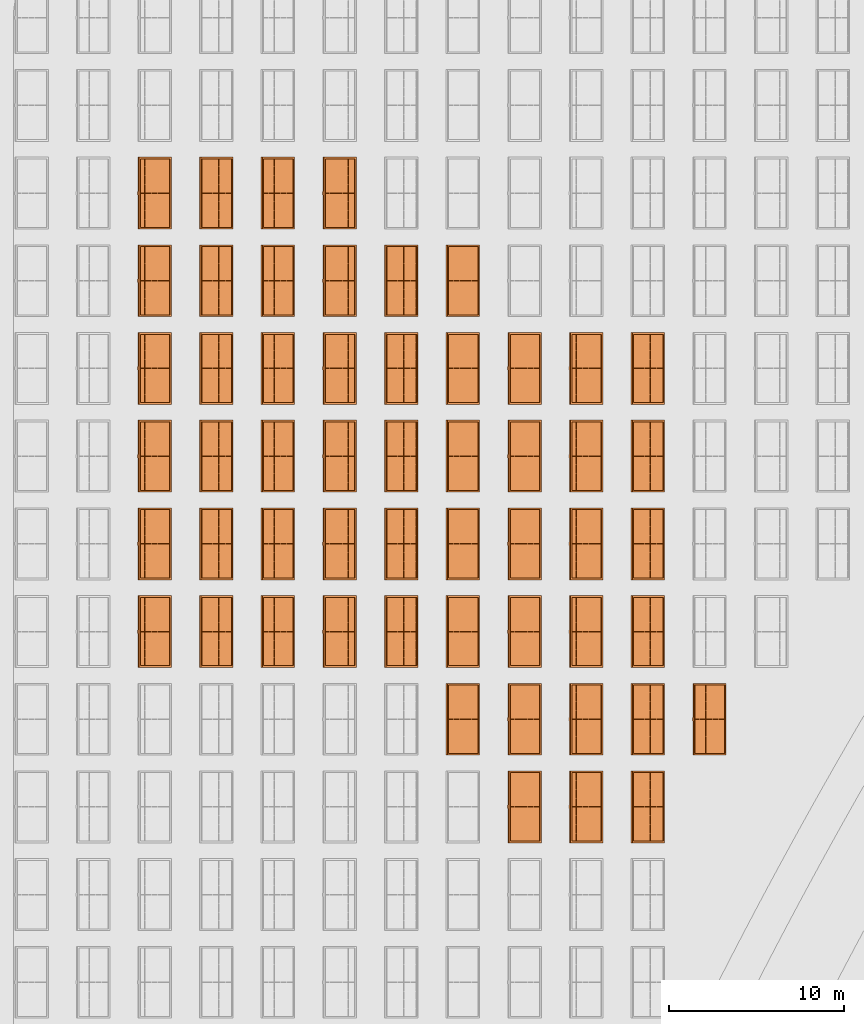
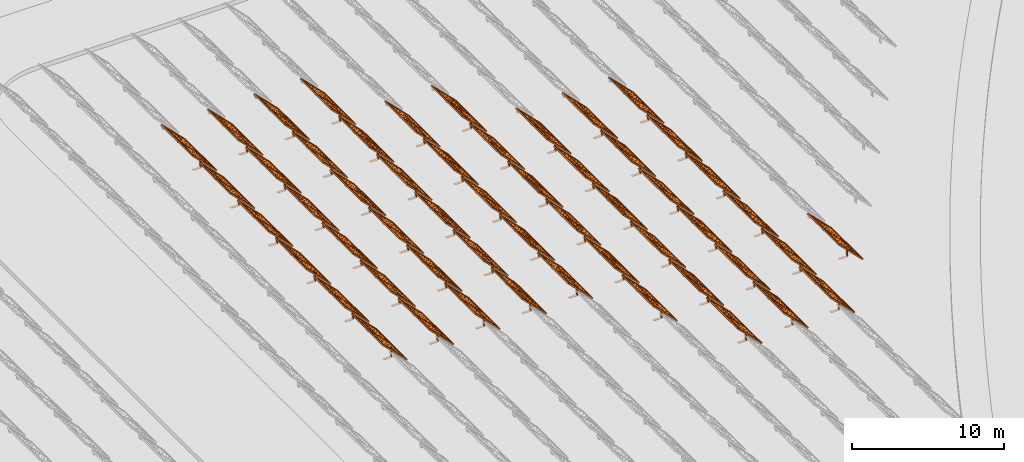
# One storey, part 31 of 39: 54 proxies.
"""IFC2X3 building model written with IfcOpenShell, lengths in millimetres."""

import ifcopenshell
import ifcopenshell.guid

model = None  # the IFC model being written
_history = None  # IfcOwnerHistory: only IFC2X3 demands one
_inside = {}  # id of a spatial element -> (the spatial element, [elements in it])
_under = {}  # id of a project, library or spatial element -> (it, [spatial elements below it])
_declared = {}  # id of a project -> (the project, [libraries it declares])
_typed = {}  # id of a type object -> (the type object, [elements of that type])
_made_of = {}  # id of a material, layer set ... -> (it, [elements and type objects made of it])


def new_model(schema):
    """Start an empty IFC model of exactly this schema.

    Asked for "IFC4X3", IfcOpenShell would pick the latest addendum, in which some entities
    have other attributes; the version numbers below select the first issue.
    IFC2X3 requires an IfcOwnerHistory on every rooted entity: one is made here for all.
    """
    global model, _history
    if schema == "IFC4X3":
        model = ifcopenshell.file(schema_version=(4, 3, 0, 0))
    else:
        model = ifcopenshell.file(schema=schema)
    _inside.clear()
    _under.clear()
    _declared.clear()
    _typed.clear()
    _made_of.clear()
    _history = None
    if model.schema == "IFC2X3":
        org = make("IfcOrganization", Name="unknown")
        user = make(
            "IfcPersonAndOrganization",
            ThePerson=make("IfcPerson", FamilyName="unknown"),
            TheOrganization=org,
        )
        app = make(
            "IfcApplication",
            ApplicationDeveloper=org,
            Version="unknown",
            ApplicationFullName="unknown",
            ApplicationIdentifier="unknown",
        )
        _history = make(
            "IfcOwnerHistory",
            OwningUser=user,
            OwningApplication=app,
            ChangeAction="ADDED",
            CreationDate=0,
        )
    return model


def make(cls, **values):
    """One entity of the class cls with the attributes given. An attribute that is None is left unset."""
    return model.create_entity(
        cls, **{name: value for name, value in values.items() if value is not None}
    )


def entity(cls, *values):
    """Any entity or typed value of the class cls, its attributes in the order of the schema. None: left unset."""
    e = model.create_entity(cls)
    for i, value in enumerate(values):
        if value is not None:
            e[i] = value
    return e


def rooted(cls, **values):
    """An entity with a GlobalId (a new one), such as an element, a storey or a relation."""
    return make(cls, GlobalId=ifcopenshell.guid.new(), OwnerHistory=_history, **values)


def si_unit(unit_type, name, prefix=None):
    """IfcSIUnit, for example si_unit("LENGTHUNIT", "METRE", prefix="MILLI")."""
    return make("IfcSIUnit", UnitType=unit_type, Prefix=prefix, Name=name)


def converted_unit(unit_type, name, factor, base, dimensions=None, offset=None):
    """IfcConversionBasedUnit, such as the inch: factor (a typed value) times the base unit."""
    return make(
        "IfcConversionBasedUnit"
        if offset is None
        else "IfcConversionBasedUnitWithOffset",
        ConversionOffset=offset,
        Dimensions=None
        if dimensions is None
        else entity("IfcDimensionalExponents", *dimensions),
        UnitType=unit_type,
        Name=name,
        ConversionFactor=make(
            "IfcMeasureWithUnit", ValueComponent=factor, UnitComponent=base
        ),
    )


def derived_unit(unit_type, elements):
    """IfcDerivedUnit: a product of units, each with its exponent."""
    return make(
        "IfcDerivedUnit",
        Elements=[
            make("IfcDerivedUnitElement", Unit=unit, Exponent=power)
            for unit, power in elements
        ],
        UnitType=unit_type,
    )


def assignment(units):
    """IfcUnitAssignment: the units of a project."""
    return None if units is None else make("IfcUnitAssignment", Units=units)


def point(xyz):
    """IfcCartesianPoint."""
    return None if xyz is None else make("IfcCartesianPoint", Coordinates=xyz)


def direction(xyz):
    """IfcDirection."""
    return None if xyz is None else make("IfcDirection", DirectionRatios=xyz)


def frame(location, z_axis=None, x_axis=None):
    """IfcAxis2Placement3D, a coordinate frame: its origin and axes. An axis left out is left unset."""
    return make(
        "IfcAxis2Placement3D",
        Location=point(location),
        Axis=direction(z_axis),
        RefDirection=direction(x_axis),
    )


def frame_2d(location, x_axis=None):
    """IfcAxis2Placement2D, a coordinate frame in the plane: its origin and x axis."""
    return make(
        "IfcAxis2Placement2D", Location=point(location), RefDirection=direction(x_axis)
    )


def origin():
    """The frame at (0, 0, 0) with its axes left unset."""
    return frame((0.0, 0.0, 0.0))


def origin_2d_with_axis():
    """The frame at (0, 0) in the plane with the x axis (1, 0) written out."""
    return frame_2d((0.0, 0.0), x_axis=(1.0, 0.0))


def place(relative_to, where):
    """IfcLocalPlacement: puts the frame where relative to a parent placement (None: the world)."""
    return make(
        "IfcLocalPlacement", PlacementRelTo=relative_to, RelativePlacement=where
    )


def context(
    kind, dimensions, precision=None, world=None, true_north=None, identifier=None
):
    """IfcGeometricRepresentationContext, for example the 3D "Model" context."""
    return make(
        "IfcGeometricRepresentationContext",
        ContextIdentifier=identifier,
        ContextType=kind,
        CoordinateSpaceDimension=dimensions,
        Precision=precision,
        WorldCoordinateSystem=world,
        TrueNorth=true_north,
    )


def subcontext(parent, identifier, kind, view, scale=None):
    """IfcGeometricRepresentationSubContext, for example "Body" below "Model"."""
    return make(
        "IfcGeometricRepresentationSubContext",
        ContextIdentifier=identifier,
        ContextType=kind,
        ParentContext=parent,
        TargetScale=scale,
        TargetView=view,
    )


def project(units=None, contexts=None):
    """IfcProject with its units and contexts."""
    return rooted(
        "IfcProject",
        Name="project",
        RepresentationContexts=contexts,
        UnitsInContext=assignment(units),
    )


def spatial(cls, under=None, at=None, **own):
    """A site, building, storey or space (cls), placed at a placement, below another one or the project."""
    s = rooted(cls, ObjectPlacement=at, **own)
    if under is not None:
        _under.setdefault(under.id(), (under, []))[1].append(s)
    return s


def polyline(points):
    """IfcPolyline through the points."""
    return make("IfcPolyline", Points=[point(p) for p in points])


def profile(cls, at=None, kind="AREA", **sizes):
    """A parametric profile (cls). Its sizes go by their IFC names, for example OverallWidth=200.0."""
    return make(cls, ProfileType=kind, Position=at, **sizes)


def rectangle(**sizes):
    """IfcRectangleProfileDef."""
    return profile("IfcRectangleProfileDef", **sizes)


def outline(outer, holes=None, kind="AREA"):
    """IfcArbitraryClosedProfileDef: a profile drawn as a closed curve; with holes, ...WithVoids."""
    if holes is None:
        return make("IfcArbitraryClosedProfileDef", ProfileType=kind, OuterCurve=outer)
    return make(
        "IfcArbitraryProfileDefWithVoids",
        ProfileType=kind,
        OuterCurve=outer,
        InnerCurves=holes,
    )


def extrude(swept, where, along, depth):
    """IfcExtrudedAreaSolid: the profile swept, set in the frame where, extruded along a direction by depth."""
    return make(
        "IfcExtrudedAreaSolid",
        SweptArea=swept,
        Position=where,
        ExtrudedDirection=direction(along),
        Depth=depth,
    )


def shape(context_of_items, identifier, shape_type, items):
    """IfcShapeRepresentation: the items that make up one representation, for example the "Body"."""
    return make(
        "IfcShapeRepresentation",
        ContextOfItems=context_of_items,
        RepresentationIdentifier=identifier,
        RepresentationType=shape_type,
        Items=items,
    )


def source(mapping_origin, context_of_items, identifier, shape_type, items):
    """IfcRepresentationMap: a shape defined once, which mapped items show again and again."""
    return make(
        "IfcRepresentationMap",
        MappingOrigin=mapping_origin,
        MappedRepresentation=shape(context_of_items, identifier, shape_type, items),
    )


def transform(
    local_origin,
    x_axis=None,
    y_axis=None,
    z_axis=None,
    scale=None,
    scale2=None,
    scale3=None,
    uniform=True,
):
    """IfcCartesianTransformationOperator3D, or its non-uniform kind. x_axis, y_axis, z_axis: its Axis1, 2, 3."""
    if uniform:
        return make(
            "IfcCartesianTransformationOperator3D",
            Axis1=direction(x_axis),
            Axis2=direction(y_axis),
            LocalOrigin=point(local_origin),
            Scale=scale,
            Axis3=direction(z_axis),
        )
    return make(
        "IfcCartesianTransformationOperator3DnonUniform",
        Axis1=direction(x_axis),
        Axis2=direction(y_axis),
        LocalOrigin=point(local_origin),
        Scale=scale,
        Axis3=direction(z_axis),
        Scale2=scale2,
        Scale3=scale3,
    )


def mapped(mapping_source, mapping_target):
    """IfcMappedItem: shows the shape of a source again, moved by a transform."""
    return make(
        "IfcMappedItem", MappingSource=mapping_source, MappingTarget=mapping_target
    )


def material(Name=None, Category=None):
    """IfcMaterial."""
    return make("IfcMaterial", Name=Name, Category=Category)


def material_list(materials):
    """IfcMaterialList."""
    return make("IfcMaterialList", Materials=materials)


def made_of(thing, what):
    """Note that an element or type object is made of a material, layer set ...; save() writes the relation."""
    if what is not None:
        _made_of.setdefault(what.id(), (what, []))[1].append(thing)
    return thing


def element(
    cls,
    number,
    at=None,
    inside=None,
    cuts=None,
    type_object=None,
    material=None,
    context=None,
    identifier="Body",
    shape_type=None,
    held_by="IfcProductDefinitionShape",
    body=None,
    shapes=None,
    **own,
):
    """One element of the class cls, such as IfcWall. Its Tag is "e" and its number.

    at: its placement. inside: the storey or other place that contains it. cuts: it is an
    opening in that element (IfcRelVoidsElement). A single representation is given by context,
    identifier, shape_type and body (its items); several are given by shapes. held_by: the class
    of the entity that holds the representations. save() writes the other relations.
    """
    e = rooted(cls, Tag="e%d" % number, ObjectPlacement=at, **own)
    if body is not None:
        shapes = [shape(context, identifier, shape_type, body)]
    if shapes is not None:
        e.Representation = make(held_by, Representations=shapes)
    if inside is not None:
        _inside.setdefault(inside.id(), (inside, []))[1].append(e)
    if cuts is not None:
        rooted(
            "IfcRelVoidsElement", RelatingBuildingElement=cuts, RelatedOpeningElement=e
        )
    if type_object is not None:
        _typed.setdefault(type_object.id(), (type_object, []))[1].append(e)
    return made_of(e, material)


def aggregate(whole, parts):
    """IfcRelAggregates: a whole, such as a stair, and the parts it consists of."""
    return rooted("IfcRelAggregates", RelatingObject=whole, RelatedObjects=parts)


def save(model, path):
    """Write the relations noted so far, then the file.

    IfcRelAggregates (storeys below a building ...), IfcRelContainedInSpatialStructure (elements
    in a storey), IfcRelDefinesByType, IfcRelAssociatesMaterial and IfcRelDeclares: one each for
    every whole, place, type object, material and project.
    """
    for whole, parts in _under.values():
        aggregate(whole, parts)
    for where, things in _inside.values():
        rooted(
            "IfcRelContainedInSpatialStructure",
            RelatedElements=things,
            RelatingStructure=where,
        )
    for kind, things in _typed.values():
        rooted("IfcRelDefinesByType", RelatedObjects=things, RelatingType=kind)
    for what, things in _made_of.values():
        rooted("IfcRelAssociatesMaterial", RelatedObjects=things, RelatingMaterial=what)
    for by, libraries in _declared.values():
        rooted("IfcRelDeclares", RelatingContext=by, RelatedDefinitions=libraries)
    model.write(path)


model = new_model("IFC2X3")

# Units and contexts
model_context = context("Model", 3, precision=1e-06, world=origin(), true_north=direction((2.0, 6.12303176911189e-17, 1.0)))
context_of_model = context(None, 3, precision=1e-06, world=origin(), true_north=direction((2.0, 6.12303176911189e-17, 1.0)))
body_context = subcontext(model_context, "Body", "Model", "MODEL_VIEW")
ifc_project = project(units=[si_unit("LENGTHUNIT", "METRE", prefix="MILLI"), si_unit("AREAUNIT", "SQUARE_METRE", prefix="MILLI"), si_unit("VOLUMEUNIT", "CUBIC_METRE", prefix="MILLI"), converted_unit("PLANEANGLEUNIT", "DEGREE", entity("IfcRatioMeasure", 0.0174532925199433), si_unit("PLANEANGLEUNIT", "RADIAN"), dimensions=[0, 0, 0, 0, 0, 0, 0]), si_unit("MASSUNIT", "GRAM", prefix="KILO"), si_unit("TIMEUNIT", "SECOND"), si_unit("THERMODYNAMICTEMPERATUREUNIT", "KELVIN"), derived_unit("THERMALTRANSMITTANCEUNIT", [(si_unit("MASSUNIT", "GRAM", prefix="KILO"), 1), (si_unit("THERMODYNAMICTEMPERATUREUNIT", "KELVIN"), -1), (si_unit("TIMEUNIT", "SECOND"), -3)]), derived_unit("VOLUMETRICFLOWRATEUNIT", [(si_unit("LENGTHUNIT", "METRE"), 3), (si_unit("TIMEUNIT", "SECOND"), -1)])], contexts=[model_context, context_of_model])

# Site, building, storey
site_placement = place(None, origin())
site = spatial("IfcSite", under=ifc_project, at=site_placement, CompositionType="ELEMENT")
building_placement = place(site_placement, origin())
building = spatial("IfcBuilding", under=site, at=building_placement, CompositionType="ELEMENT")
storey_placement = place(building_placement, frame((0.0, 0.0, 4000.0)))
storey = spatial("IfcBuildingStorey", under=building, at=storey_placement, Name="Level 2", CompositionType="ELEMENT", Elevation=4000.0)

# Proxies
ifc_material_1 = material(Name="Stand-Steel")
ifc_material_2 = material(Name="Aluminium")
ifc_material_3 = material(Name="Glass")
ifc_material_list_1 = material_list([ifc_material_1, ifc_material_2, ifc_material_3])
shared_shape = source(origin(), body_context, "Body", "SweptSolid", [
    extrude(outline(polyline([(-629.526235435404, -220.0), (329.763117717702, -220.0), (329.763117717703, 410.0), (299.763117717703, 410.0), (299.763117717702, -190.0), (-629.526235435404, -190.0), (-629.526235435404, -220.0)])), frame((-190.00003127179, -100.0, 299.763117717707), z_axis=(0.0, 1.0, 0.0), x_axis=(0.0, 0.0, -1.0)), (0.0, 0.0, 1.0), 200.0),
    extrude(rectangle(XDim=20.0000000000001, YDim=200.0, at=frame_2d((0.0, -7.105427357601e-14), x_axis=(0.0, 1.0))), frame((-7.07109908365613, 0.0, 922.21828534124), z_axis=(-0.70710678118654, 0.0, 0.707106781186555), x_axis=(0.0, 1.0, 0.0)), (0.0, 0.0, 1.0), 2600.0),
    extrude(rectangle(XDim=24.9999999999997, YDim=24.9999999999999, at=frame_2d((2.87769807982841e-13, -9.50350909079134e-14), x_axis=(1.0, 0.0))), frame((-1449.56292018118, -1950.0, 2449.57494522722), z_axis=(0.0, 1.0, 0.0), x_axis=(-0.707106781186548, 0.0, -0.707106781186548)), (0.0, 0.0, 1.0), 3900.0),
    extrude(rectangle(XDim=24.9999999999999, YDim=25.0000000000001, at=origin_2d_with_axis()), frame((-1096.0095295879, -1950.0, 2096.02155463395), z_axis=(0.0, 1.0, 0.0), x_axis=(-0.707106781186542, 0.0, -0.707106781186553)), (0.0, 0.0, 1.0), 3900.0),
    extrude(rectangle(XDim=24.9999999999999, YDim=25.0000000000001, at=origin_2d_with_axis()), frame((-742.456138994631, -1950.0, 1742.46816404067), z_axis=(0.0, 1.0, 0.0), x_axis=(-0.707106781186542, 0.0, -0.707106781186553)), (0.0, 0.0, 1.0), 3900.0),
    extrude(rectangle(XDim=25.0, YDim=24.9999999999997, at=frame_2d((-7.19424519957101e-14, 1.19904086659517e-13), x_axis=(1.0, 0.0))), frame((-388.902748401358, -1950.0, 1388.9147734474), z_axis=(0.0, 1.0, 0.0), x_axis=(-0.707106781186545, 0.0, -0.70710678118655)), (0.0, 0.0, 1.0), 3900.0),
    extrude(rectangle(XDim=25.0000000000002, YDim=25.0, at=frame_2d((1.35891298214119e-13, 6.21724893790088e-15), x_axis=(0.0, 1.0))), frame((-35.3553703311048, 1500.0, 1035.35537033109), z_axis=(-0.707106781186544, 0.0, 0.707106781186551), x_axis=(0.0, 1.0, 0.0)), (0.0, 0.0, 1.0), 2440.0),
    extrude(rectangle(XDim=25.0000000000002, YDim=25.0, at=frame_2d((0.0, 1.77635683940025e-15), x_axis=(0.0, 1.0))), frame((-35.3553703311059, 1000.0, 1035.35537033109), z_axis=(-0.707106781186546, 0.0, 0.707106781186549), x_axis=(0.0, 1.0, 0.0)), (0.0, 0.0, 1.0), 2440.0),
    extrude(rectangle(XDim=25.0000000000002, YDim=25.0, at=frame_2d((0.0, 8.43769498715119e-14), x_axis=(0.0, 1.0))), frame((-26.5165355662756, 0.0, 1044.19420509593), z_axis=(-0.707106781186546, 0.0, 0.707106781186549), x_axis=(0.0, -1.0, 0.0)), (0.0, 0.0, 1.0), 2440.0),
    extrude(rectangle(XDim=25.0000000000002, YDim=25.0, at=frame_2d((0.0, 8.88178419700125e-16), x_axis=(0.0, 1.0))), frame((-35.3553703311065, 500.0, 1035.35537033109), z_axis=(-0.707106781186546, 0.0, 0.707106781186549), x_axis=(0.0, 1.0, 0.0)), (0.0, 0.0, 1.0), 2440.0),
    extrude(rectangle(XDim=25.0000000000002, YDim=25.0, at=frame_2d((0.0, 8.88178419700125e-16), x_axis=(0.0, 1.0))), frame((-35.3553703311086, -500.0, 1035.35537033109), z_axis=(-0.707106781186546, 0.0, 0.707106781186549), x_axis=(0.0, 1.0, 0.0)), (0.0, 0.0, 1.0), 2440.0),
    extrude(rectangle(XDim=25.0000000000002, YDim=25.0, at=frame_2d((0.0, 8.88178419700125e-16), x_axis=(0.0, 1.0))), frame((-35.3553703311095, -1000.0, 1035.35537033109), z_axis=(-0.707106781186546, 0.0, 0.707106781186549), x_axis=(0.0, 1.0, 0.0)), (0.0, 0.0, 1.0), 2440.0),
    extrude(rectangle(XDim=25.0000000000002, YDim=25.0, at=frame_2d((1.35891298214119e-13, 1.77635683940025e-15), x_axis=(0.0, 1.0))), frame((-35.3553703311107, -1500.0, 1035.35537033109), z_axis=(-0.707106781186546, 0.0, 0.707106781186549), x_axis=(0.0, 1.0, 0.0)), (0.0, 0.0, 1.0), 2440.0),
    extrude(rectangle(XDim=2400.0, YDim=11.9999999999994, at=frame_2d((-1.13686837721616e-13, 2.02948768901479e-13), x_axis=(1.0, 0.0))), frame((-883.883507754966, -1950.0, 1883.88350775495), z_axis=(0.0, 1.0, 0.0), x_axis=(0.707106781186546, 0.0, -0.707106781186549)), (0.0, 0.0, 1.0), 3900.0),
    extrude(outline(polyline([(-2050.0, -1300.0), (2050.0, -1300.0), (2050.0, 1300.0), (-2050.0, 1300.0), (-2050.0, -1300.0)]), holes=[polyline([(1950.0, -1200.0), (-1950.0, -1200.0), (-1950.0, 1200.0), (1950.0, 1200.0), (1950.0, -1200.0)])]), frame((-919.238846814293, 0.0, 1848.52816869563), z_axis=(0.707106781186554, 0.0, 0.707106781186541), x_axis=(0.0, 1.0, 0.0)), (0.0, 0.0, 1.0), 99.9999999999898),
])
proxy_1_placement = place(storey_placement, frame((-140870.317940101, 595144.680552408, 30.0)))
element("IfcBuildingElementProxy", 1, at=proxy_1_placement, inside=storey, material=ifc_material_list_1, Name="Solar Panel_4000X2500:Solar Panel_4000X2500", ObjectType="Solar Panel_4000X2500", CompositionType="ELEMENT", context=body_context, shape_type="MappedRepresentation", body=[
    mapped(shared_shape, transform((0.0, 0.0, 0.0), scale=1.0)),
])
ifc_material_list_2 = material_list([ifc_material_1, ifc_material_2, ifc_material_3])
proxy_2_placement = place(storey_placement, frame((-137355.307568371, 595144.680552408, 30.0)))
element("IfcBuildingElementProxy", 2, at=proxy_2_placement, inside=storey, material=ifc_material_list_2, Name="Solar Panel_4000X2500:Solar Panel_4000X2500", ObjectType="Solar Panel_4000X2500", CompositionType="ELEMENT", context=body_context, shape_type="MappedRepresentation", body=[
    mapped(shared_shape, transform((0.0, 0.0, 0.0), scale=1.0)),
])
ifc_material_list_3 = material_list([ifc_material_1, ifc_material_2, ifc_material_3])
proxy_3_placement = place(storey_placement, frame((-133840.297196641, 595144.680552408, 30.0)))
element("IfcBuildingElementProxy", 3, at=proxy_3_placement, inside=storey, material=ifc_material_list_3, Name="Solar Panel_4000X2500:Solar Panel_4000X2500", ObjectType="Solar Panel_4000X2500", CompositionType="ELEMENT", context=body_context, shape_type="MappedRepresentation", body=[
    mapped(shared_shape, transform((0.0, 0.0, 0.0), scale=1.0)),
])
ifc_material_list_4 = material_list([ifc_material_1, ifc_material_2, ifc_material_3])
proxy_4_placement = place(storey_placement, frame((-130325.286824911, 595144.680552408, 30.0)))
element("IfcBuildingElementProxy", 4, at=proxy_4_placement, inside=storey, material=ifc_material_list_4, Name="Solar Panel_4000X2500:Solar Panel_4000X2500", ObjectType="Solar Panel_4000X2500", CompositionType="ELEMENT", context=body_context, shape_type="MappedRepresentation", body=[
    mapped(shared_shape, transform((0.0, 0.0, 0.0), scale=1.0)),
])
ifc_material_list_5 = material_list([ifc_material_1, ifc_material_2, ifc_material_3])
proxy_5_placement = place(storey_placement, frame((-140870.317940101, 600144.680552408, 30.0)))
element("IfcBuildingElementProxy", 5, at=proxy_5_placement, inside=storey, material=ifc_material_list_5, Name="Solar Panel_4000X2500:Solar Panel_4000X2500", ObjectType="Solar Panel_4000X2500", CompositionType="ELEMENT", context=body_context, shape_type="MappedRepresentation", body=[
    mapped(shared_shape, transform((0.0, 0.0, 0.0), scale=1.0)),
])
ifc_material_list_6 = material_list([ifc_material_1, ifc_material_2, ifc_material_3])
proxy_6_placement = place(storey_placement, frame((-137355.307568371, 600144.680552408, 30.0)))
element("IfcBuildingElementProxy", 6, at=proxy_6_placement, inside=storey, material=ifc_material_list_6, Name="Solar Panel_4000X2500:Solar Panel_4000X2500", ObjectType="Solar Panel_4000X2500", CompositionType="ELEMENT", context=body_context, shape_type="MappedRepresentation", body=[
    mapped(shared_shape, transform((0.0, 0.0, 0.0), scale=1.0)),
])
ifc_material_list_7 = material_list([ifc_material_1, ifc_material_2, ifc_material_3])
proxy_7_placement = place(storey_placement, frame((-133840.297196641, 600144.680552408, 30.0)))
element("IfcBuildingElementProxy", 7, at=proxy_7_placement, inside=storey, material=ifc_material_list_7, Name="Solar Panel_4000X2500:Solar Panel_4000X2500", ObjectType="Solar Panel_4000X2500", CompositionType="ELEMENT", context=body_context, shape_type="MappedRepresentation", body=[
    mapped(shared_shape, transform((0.0, 0.0, 0.0), scale=1.0)),
])
ifc_material_list_8 = material_list([ifc_material_1, ifc_material_2, ifc_material_3])
proxy_8_placement = place(storey_placement, frame((-130325.286824911, 600144.680552408, 30.0)))
element("IfcBuildingElementProxy", 8, at=proxy_8_placement, inside=storey, material=ifc_material_list_8, Name="Solar Panel_4000X2500:Solar Panel_4000X2500", ObjectType="Solar Panel_4000X2500", CompositionType="ELEMENT", context=body_context, shape_type="MappedRepresentation", body=[
    mapped(shared_shape, transform((0.0, 0.0, 0.0), scale=1.0)),
])
ifc_material_list_9 = material_list([ifc_material_1, ifc_material_2, ifc_material_3])
proxy_9_placement = place(storey_placement, frame((-140870.317940101, 605144.680552408, 30.0)))
element("IfcBuildingElementProxy", 9, at=proxy_9_placement, inside=storey, material=ifc_material_list_9, Name="Solar Panel_4000X2500:Solar Panel_4000X2500", ObjectType="Solar Panel_4000X2500", CompositionType="ELEMENT", context=body_context, shape_type="MappedRepresentation", body=[
    mapped(shared_shape, transform((0.0, 0.0, 0.0), scale=1.0)),
])
ifc_material_list_10 = material_list([ifc_material_1, ifc_material_2, ifc_material_3])
proxy_10_placement = place(storey_placement, frame((-137355.307568371, 605144.680552408, 30.0)))
element("IfcBuildingElementProxy", 10, at=proxy_10_placement, inside=storey, material=ifc_material_list_10, Name="Solar Panel_4000X2500:Solar Panel_4000X2500", ObjectType="Solar Panel_4000X2500", CompositionType="ELEMENT", context=body_context, shape_type="MappedRepresentation", body=[
    mapped(shared_shape, transform((0.0, 0.0, 0.0), scale=1.0)),
])
ifc_material_list_11 = material_list([ifc_material_1, ifc_material_2, ifc_material_3])
proxy_11_placement = place(storey_placement, frame((-133840.297196641, 605144.680552408, 30.0)))
element("IfcBuildingElementProxy", 11, at=proxy_11_placement, inside=storey, material=ifc_material_list_11, Name="Solar Panel_4000X2500:Solar Panel_4000X2500", ObjectType="Solar Panel_4000X2500", CompositionType="ELEMENT", context=body_context, shape_type="MappedRepresentation", body=[
    mapped(shared_shape, transform((0.0, 0.0, 0.0), scale=1.0)),
])
ifc_material_list_12 = material_list([ifc_material_1, ifc_material_2, ifc_material_3])
proxy_12_placement = place(storey_placement, frame((-130325.286824911, 605144.680552408, 30.0)))
element("IfcBuildingElementProxy", 12, at=proxy_12_placement, inside=storey, material=ifc_material_list_12, Name="Solar Panel_4000X2500:Solar Panel_4000X2500", ObjectType="Solar Panel_4000X2500", CompositionType="ELEMENT", context=body_context, shape_type="MappedRepresentation", body=[
    mapped(shared_shape, transform((0.0, 0.0, 0.0), scale=1.0)),
])
ifc_material_list_13 = material_list([ifc_material_1, ifc_material_2, ifc_material_3])
proxy_13_placement = place(storey_placement, frame((-140870.317940101, 610144.680552408, 30.0)))
element("IfcBuildingElementProxy", 13, at=proxy_13_placement, inside=storey, material=ifc_material_list_13, Name="Solar Panel_4000X2500:Solar Panel_4000X2500", ObjectType="Solar Panel_4000X2500", CompositionType="ELEMENT", context=body_context, shape_type="MappedRepresentation", body=[
    mapped(shared_shape, transform((0.0, 0.0, 0.0), scale=1.0)),
])
ifc_material_list_14 = material_list([ifc_material_1, ifc_material_2, ifc_material_3])
proxy_14_placement = place(storey_placement, frame((-137355.307568371, 610144.680552408, 30.0)))
element("IfcBuildingElementProxy", 14, at=proxy_14_placement, inside=storey, material=ifc_material_list_14, Name="Solar Panel_4000X2500:Solar Panel_4000X2500", ObjectType="Solar Panel_4000X2500", CompositionType="ELEMENT", context=body_context, shape_type="MappedRepresentation", body=[
    mapped(shared_shape, transform((0.0, 0.0, 0.0), scale=1.0)),
])
ifc_material_list_15 = material_list([ifc_material_1, ifc_material_2, ifc_material_3])
proxy_15_placement = place(storey_placement, frame((-133840.297196641, 610144.680552408, 30.0)))
element("IfcBuildingElementProxy", 15, at=proxy_15_placement, inside=storey, material=ifc_material_list_15, Name="Solar Panel_4000X2500:Solar Panel_4000X2500", ObjectType="Solar Panel_4000X2500", CompositionType="ELEMENT", context=body_context, shape_type="MappedRepresentation", body=[
    mapped(shared_shape, transform((0.0, 0.0, 0.0), scale=1.0)),
])
ifc_material_list_16 = material_list([ifc_material_1, ifc_material_2, ifc_material_3])
proxy_16_placement = place(storey_placement, frame((-130325.286824911, 610144.680552408, 30.0)))
element("IfcBuildingElementProxy", 16, at=proxy_16_placement, inside=storey, material=ifc_material_list_16, Name="Solar Panel_4000X2500:Solar Panel_4000X2500", ObjectType="Solar Panel_4000X2500", CompositionType="ELEMENT", context=body_context, shape_type="MappedRepresentation", body=[
    mapped(shared_shape, transform((0.0, 0.0, 0.0), scale=1.0)),
])
ifc_material_list_17 = material_list([ifc_material_1, ifc_material_2, ifc_material_3])
proxy_17_placement = place(storey_placement, frame((-140870.317940101, 615144.680552408, 30.0)))
element("IfcBuildingElementProxy", 17, at=proxy_17_placement, inside=storey, material=ifc_material_list_17, Name="Solar Panel_4000X2500:Solar Panel_4000X2500", ObjectType="Solar Panel_4000X2500", CompositionType="ELEMENT", context=body_context, shape_type="MappedRepresentation", body=[
    mapped(shared_shape, transform((0.0, 0.0, 0.0), scale=1.0)),
])
ifc_material_list_18 = material_list([ifc_material_1, ifc_material_2, ifc_material_3])
proxy_18_placement = place(storey_placement, frame((-137355.307568371, 615144.680552408, 30.0)))
element("IfcBuildingElementProxy", 18, at=proxy_18_placement, inside=storey, material=ifc_material_list_18, Name="Solar Panel_4000X2500:Solar Panel_4000X2500", ObjectType="Solar Panel_4000X2500", CompositionType="ELEMENT", context=body_context, shape_type="MappedRepresentation", body=[
    mapped(shared_shape, transform((0.0, 0.0, 0.0), scale=1.0)),
])
ifc_material_list_19 = material_list([ifc_material_1, ifc_material_2, ifc_material_3])
proxy_19_placement = place(storey_placement, frame((-133840.297196641, 615144.680552408, 30.0)))
element("IfcBuildingElementProxy", 19, at=proxy_19_placement, inside=storey, material=ifc_material_list_19, Name="Solar Panel_4000X2500:Solar Panel_4000X2500", ObjectType="Solar Panel_4000X2500", CompositionType="ELEMENT", context=body_context, shape_type="MappedRepresentation", body=[
    mapped(shared_shape, transform((0.0, 0.0, 0.0), scale=1.0)),
])
ifc_material_list_20 = material_list([ifc_material_1, ifc_material_2, ifc_material_3])
proxy_20_placement = place(storey_placement, frame((-130325.286824911, 615144.680552408, 30.0)))
element("IfcBuildingElementProxy", 20, at=proxy_20_placement, inside=storey, material=ifc_material_list_20, Name="Solar Panel_4000X2500:Solar Panel_4000X2500", ObjectType="Solar Panel_4000X2500", CompositionType="ELEMENT", context=body_context, shape_type="MappedRepresentation", body=[
    mapped(shared_shape, transform((0.0, 0.0, 0.0), scale=1.0)),
])
ifc_material_list_21 = material_list([ifc_material_1, ifc_material_2, ifc_material_3])
proxy_21_placement = place(storey_placement, frame((-140870.317940101, 620144.680552408, 30.0)))
element("IfcBuildingElementProxy", 21, at=proxy_21_placement, inside=storey, material=ifc_material_list_21, Name="Solar Panel_4000X2500:Solar Panel_4000X2500", ObjectType="Solar Panel_4000X2500", CompositionType="ELEMENT", context=body_context, shape_type="MappedRepresentation", body=[
    mapped(shared_shape, transform((0.0, 0.0, 0.0), scale=1.0)),
])
ifc_material_list_22 = material_list([ifc_material_1, ifc_material_2, ifc_material_3])
proxy_22_placement = place(storey_placement, frame((-137355.307568371, 620144.680552408, 30.0)))
element("IfcBuildingElementProxy", 22, at=proxy_22_placement, inside=storey, material=ifc_material_list_22, Name="Solar Panel_4000X2500:Solar Panel_4000X2500", ObjectType="Solar Panel_4000X2500", CompositionType="ELEMENT", context=body_context, shape_type="MappedRepresentation", body=[
    mapped(shared_shape, transform((0.0, 0.0, 0.0), scale=1.0)),
])
ifc_material_list_23 = material_list([ifc_material_1, ifc_material_2, ifc_material_3])
proxy_23_placement = place(storey_placement, frame((-133840.297196641, 620144.680552408, 30.0)))
element("IfcBuildingElementProxy", 23, at=proxy_23_placement, inside=storey, material=ifc_material_list_23, Name="Solar Panel_4000X2500:Solar Panel_4000X2500", ObjectType="Solar Panel_4000X2500", CompositionType="ELEMENT", context=body_context, shape_type="MappedRepresentation", body=[
    mapped(shared_shape, transform((0.0, 0.0, 0.0), scale=1.0)),
])
ifc_material_list_24 = material_list([ifc_material_1, ifc_material_2, ifc_material_3])
proxy_24_placement = place(storey_placement, frame((-130325.286824911, 620144.680552408, 30.0)))
element("IfcBuildingElementProxy", 24, at=proxy_24_placement, inside=storey, material=ifc_material_list_24, Name="Solar Panel_4000X2500:Solar Panel_4000X2500", ObjectType="Solar Panel_4000X2500", CompositionType="ELEMENT", context=body_context, shape_type="MappedRepresentation", body=[
    mapped(shared_shape, transform((0.0, 0.0, 0.0), scale=1.0)),
])
ifc_material_list_25 = material_list([ifc_material_1, ifc_material_2, ifc_material_3])
proxy_25_placement = place(storey_placement, frame((-126810.276453181, 595144.680552408, 30.0)))
element("IfcBuildingElementProxy", 25, at=proxy_25_placement, inside=storey, material=ifc_material_list_25, Name="Solar Panel_4000X2500:Solar Panel_4000X2500", ObjectType="Solar Panel_4000X2500", CompositionType="ELEMENT", context=body_context, shape_type="MappedRepresentation", body=[
    mapped(shared_shape, transform((0.0, 0.0, 0.0), scale=1.0)),
])
ifc_material_list_26 = material_list([ifc_material_1, ifc_material_2, ifc_material_3])
proxy_26_placement = place(storey_placement, frame((-126810.276453181, 600144.680552408, 30.0)))
element("IfcBuildingElementProxy", 26, at=proxy_26_placement, inside=storey, material=ifc_material_list_26, Name="Solar Panel_4000X2500:Solar Panel_4000X2500", ObjectType="Solar Panel_4000X2500", CompositionType="ELEMENT", context=body_context, shape_type="MappedRepresentation", body=[
    mapped(shared_shape, transform((0.0, 0.0, 0.0), scale=1.0)),
])
ifc_material_list_27 = material_list([ifc_material_1, ifc_material_2, ifc_material_3])
proxy_27_placement = place(storey_placement, frame((-126810.276453181, 605144.680552408, 30.0)))
element("IfcBuildingElementProxy", 27, at=proxy_27_placement, inside=storey, material=ifc_material_list_27, Name="Solar Panel_4000X2500:Solar Panel_4000X2500", ObjectType="Solar Panel_4000X2500", CompositionType="ELEMENT", context=body_context, shape_type="MappedRepresentation", body=[
    mapped(shared_shape, transform((0.0, 0.0, 0.0), scale=1.0)),
])
ifc_material_list_28 = material_list([ifc_material_1, ifc_material_2, ifc_material_3])
proxy_28_placement = place(storey_placement, frame((-126810.276453181, 610144.680552408, 30.0)))
element("IfcBuildingElementProxy", 28, at=proxy_28_placement, inside=storey, material=ifc_material_list_28, Name="Solar Panel_4000X2500:Solar Panel_4000X2500", ObjectType="Solar Panel_4000X2500", CompositionType="ELEMENT", context=body_context, shape_type="MappedRepresentation", body=[
    mapped(shared_shape, transform((0.0, 0.0, 0.0), scale=1.0)),
])
ifc_material_list_29 = material_list([ifc_material_1, ifc_material_2, ifc_material_3])
proxy_29_placement = place(storey_placement, frame((-126810.276453181, 615144.680552408, 30.0)))
element("IfcBuildingElementProxy", 29, at=proxy_29_placement, inside=storey, material=ifc_material_list_29, Name="Solar Panel_4000X2500:Solar Panel_4000X2500", ObjectType="Solar Panel_4000X2500", CompositionType="ELEMENT", context=body_context, shape_type="MappedRepresentation", body=[
    mapped(shared_shape, transform((0.0, 0.0, 0.0), scale=1.0)),
])
ifc_material_list_30 = material_list([ifc_material_1, ifc_material_2, ifc_material_3])
proxy_30_placement = place(storey_placement, frame((-123295.266081452, 590144.680552408, 30.0)))
element("IfcBuildingElementProxy", 30, at=proxy_30_placement, inside=storey, material=ifc_material_list_30, Name="Solar Panel_4000X2500:Solar Panel_4000X2500", ObjectType="Solar Panel_4000X2500", CompositionType="ELEMENT", context=body_context, shape_type="MappedRepresentation", body=[
    mapped(shared_shape, transform((0.0, 0.0, 0.0), scale=1.0)),
])
ifc_material_list_31 = material_list([ifc_material_1, ifc_material_2, ifc_material_3])
proxy_31_placement = place(storey_placement, frame((-123295.266081452, 595144.680552408, 30.0)))
element("IfcBuildingElementProxy", 31, at=proxy_31_placement, inside=storey, material=ifc_material_list_31, Name="Solar Panel_4000X2500:Solar Panel_4000X2500", ObjectType="Solar Panel_4000X2500", CompositionType="ELEMENT", context=body_context, shape_type="MappedRepresentation", body=[
    mapped(shared_shape, transform((0.0, 0.0, 0.0), scale=1.0)),
])
ifc_material_list_32 = material_list([ifc_material_1, ifc_material_2, ifc_material_3])
proxy_32_placement = place(storey_placement, frame((-123295.266081452, 600144.680552408, 30.0)))
element("IfcBuildingElementProxy", 32, at=proxy_32_placement, inside=storey, material=ifc_material_list_32, Name="Solar Panel_4000X2500:Solar Panel_4000X2500", ObjectType="Solar Panel_4000X2500", CompositionType="ELEMENT", context=body_context, shape_type="MappedRepresentation", body=[
    mapped(shared_shape, transform((0.0, 0.0, 0.0), scale=1.0)),
])
ifc_material_list_33 = material_list([ifc_material_1, ifc_material_2, ifc_material_3])
proxy_33_placement = place(storey_placement, frame((-123295.266081452, 605144.680552408, 30.0)))
element("IfcBuildingElementProxy", 33, at=proxy_33_placement, inside=storey, material=ifc_material_list_33, Name="Solar Panel_4000X2500:Solar Panel_4000X2500", ObjectType="Solar Panel_4000X2500", CompositionType="ELEMENT", context=body_context, shape_type="MappedRepresentation", body=[
    mapped(shared_shape, transform((0.0, 0.0, 0.0), scale=1.0)),
])
ifc_material_list_34 = material_list([ifc_material_1, ifc_material_2, ifc_material_3])
proxy_34_placement = place(storey_placement, frame((-123295.266081452, 610144.680552408, 30.0)))
element("IfcBuildingElementProxy", 34, at=proxy_34_placement, inside=storey, material=ifc_material_list_34, Name="Solar Panel_4000X2500:Solar Panel_4000X2500", ObjectType="Solar Panel_4000X2500", CompositionType="ELEMENT", context=body_context, shape_type="MappedRepresentation", body=[
    mapped(shared_shape, transform((0.0, 0.0, 0.0), scale=1.0)),
])
ifc_material_list_35 = material_list([ifc_material_1, ifc_material_2, ifc_material_3])
proxy_35_placement = place(storey_placement, frame((-123295.266081452, 615144.680552408, 30.0)))
element("IfcBuildingElementProxy", 35, at=proxy_35_placement, inside=storey, material=ifc_material_list_35, Name="Solar Panel_4000X2500:Solar Panel_4000X2500", ObjectType="Solar Panel_4000X2500", CompositionType="ELEMENT", context=body_context, shape_type="MappedRepresentation", body=[
    mapped(shared_shape, transform((0.0, 0.0, 0.0), scale=1.0)),
])
ifc_material_list_36 = material_list([ifc_material_1, ifc_material_2, ifc_material_3])
proxy_36_placement = place(storey_placement, frame((-119780.255709722, 585144.680552408, 30.0)))
element("IfcBuildingElementProxy", 36, at=proxy_36_placement, inside=storey, material=ifc_material_list_36, Name="Solar Panel_4000X2500:Solar Panel_4000X2500", ObjectType="Solar Panel_4000X2500", CompositionType="ELEMENT", context=body_context, shape_type="MappedRepresentation", body=[
    mapped(shared_shape, transform((0.0, 0.0, 0.0), scale=1.0)),
])
ifc_material_list_37 = material_list([ifc_material_1, ifc_material_2, ifc_material_3])
proxy_37_placement = place(storey_placement, frame((-119780.255709722, 590144.680552408, 30.0)))
element("IfcBuildingElementProxy", 37, at=proxy_37_placement, inside=storey, material=ifc_material_list_37, Name="Solar Panel_4000X2500:Solar Panel_4000X2500", ObjectType="Solar Panel_4000X2500", CompositionType="ELEMENT", context=body_context, shape_type="MappedRepresentation", body=[
    mapped(shared_shape, transform((0.0, 0.0, 0.0), scale=1.0)),
])
ifc_material_list_38 = material_list([ifc_material_1, ifc_material_2, ifc_material_3])
proxy_38_placement = place(storey_placement, frame((-119780.255709722, 595144.680552408, 30.0)))
element("IfcBuildingElementProxy", 38, at=proxy_38_placement, inside=storey, material=ifc_material_list_38, Name="Solar Panel_4000X2500:Solar Panel_4000X2500", ObjectType="Solar Panel_4000X2500", CompositionType="ELEMENT", context=body_context, shape_type="MappedRepresentation", body=[
    mapped(shared_shape, transform((0.0, 0.0, 0.0), scale=1.0)),
])
ifc_material_list_39 = material_list([ifc_material_1, ifc_material_2, ifc_material_3])
proxy_39_placement = place(storey_placement, frame((-119780.255709722, 600144.680552408, 30.0)))
element("IfcBuildingElementProxy", 39, at=proxy_39_placement, inside=storey, material=ifc_material_list_39, Name="Solar Panel_4000X2500:Solar Panel_4000X2500", ObjectType="Solar Panel_4000X2500", CompositionType="ELEMENT", context=body_context, shape_type="MappedRepresentation", body=[
    mapped(shared_shape, transform((0.0, 0.0, 0.0), scale=1.0)),
])
ifc_material_list_40 = material_list([ifc_material_1, ifc_material_2, ifc_material_3])
proxy_40_placement = place(storey_placement, frame((-119780.255709722, 605144.680552408, 30.0)))
element("IfcBuildingElementProxy", 40, at=proxy_40_placement, inside=storey, material=ifc_material_list_40, Name="Solar Panel_4000X2500:Solar Panel_4000X2500", ObjectType="Solar Panel_4000X2500", CompositionType="ELEMENT", context=body_context, shape_type="MappedRepresentation", body=[
    mapped(shared_shape, transform((0.0, 0.0, 0.0), scale=1.0)),
])
ifc_material_list_41 = material_list([ifc_material_1, ifc_material_2, ifc_material_3])
proxy_41_placement = place(storey_placement, frame((-119780.255709722, 610144.680552408, 30.0)))
element("IfcBuildingElementProxy", 41, at=proxy_41_placement, inside=storey, material=ifc_material_list_41, Name="Solar Panel_4000X2500:Solar Panel_4000X2500", ObjectType="Solar Panel_4000X2500", CompositionType="ELEMENT", context=body_context, shape_type="MappedRepresentation", body=[
    mapped(shared_shape, transform((0.0, 0.0, 0.0), scale=1.0)),
])
ifc_material_list_42 = material_list([ifc_material_1, ifc_material_2, ifc_material_3])
proxy_42_placement = place(storey_placement, frame((-116265.245337992, 585144.680552408, 30.0)))
element("IfcBuildingElementProxy", 42, at=proxy_42_placement, inside=storey, material=ifc_material_list_42, Name="Solar Panel_4000X2500:Solar Panel_4000X2500", ObjectType="Solar Panel_4000X2500", CompositionType="ELEMENT", context=body_context, shape_type="MappedRepresentation", body=[
    mapped(shared_shape, transform((0.0, 0.0, 0.0), scale=1.0)),
])
ifc_material_list_43 = material_list([ifc_material_1, ifc_material_2, ifc_material_3])
proxy_43_placement = place(storey_placement, frame((-116265.245337992, 590144.680552408, 30.0)))
element("IfcBuildingElementProxy", 43, at=proxy_43_placement, inside=storey, material=ifc_material_list_43, Name="Solar Panel_4000X2500:Solar Panel_4000X2500", ObjectType="Solar Panel_4000X2500", CompositionType="ELEMENT", context=body_context, shape_type="MappedRepresentation", body=[
    mapped(shared_shape, transform((0.0, 0.0, 0.0), scale=1.0)),
])
ifc_material_list_44 = material_list([ifc_material_1, ifc_material_2, ifc_material_3])
proxy_44_placement = place(storey_placement, frame((-116265.245337992, 595144.680552408, 30.0)))
element("IfcBuildingElementProxy", 44, at=proxy_44_placement, inside=storey, material=ifc_material_list_44, Name="Solar Panel_4000X2500:Solar Panel_4000X2500", ObjectType="Solar Panel_4000X2500", CompositionType="ELEMENT", context=body_context, shape_type="MappedRepresentation", body=[
    mapped(shared_shape, transform((0.0, 0.0, 0.0), scale=1.0)),
])
ifc_material_list_45 = material_list([ifc_material_1, ifc_material_2, ifc_material_3])
proxy_45_placement = place(storey_placement, frame((-116265.245337992, 600144.680552408, 30.0)))
element("IfcBuildingElementProxy", 45, at=proxy_45_placement, inside=storey, material=ifc_material_list_45, Name="Solar Panel_4000X2500:Solar Panel_4000X2500", ObjectType="Solar Panel_4000X2500", CompositionType="ELEMENT", context=body_context, shape_type="MappedRepresentation", body=[
    mapped(shared_shape, transform((0.0, 0.0, 0.0), scale=1.0)),
])
ifc_material_list_46 = material_list([ifc_material_1, ifc_material_2, ifc_material_3])
proxy_46_placement = place(storey_placement, frame((-116265.245337992, 605144.680552408, 30.0)))
element("IfcBuildingElementProxy", 46, at=proxy_46_placement, inside=storey, material=ifc_material_list_46, Name="Solar Panel_4000X2500:Solar Panel_4000X2500", ObjectType="Solar Panel_4000X2500", CompositionType="ELEMENT", context=body_context, shape_type="MappedRepresentation", body=[
    mapped(shared_shape, transform((0.0, 0.0, 0.0), scale=1.0)),
])
ifc_material_list_47 = material_list([ifc_material_1, ifc_material_2, ifc_material_3])
proxy_47_placement = place(storey_placement, frame((-116265.245337992, 610144.680552408, 30.0)))
element("IfcBuildingElementProxy", 47, at=proxy_47_placement, inside=storey, material=ifc_material_list_47, Name="Solar Panel_4000X2500:Solar Panel_4000X2500", ObjectType="Solar Panel_4000X2500", CompositionType="ELEMENT", context=body_context, shape_type="MappedRepresentation", body=[
    mapped(shared_shape, transform((0.0, 0.0, 0.0), scale=1.0)),
])
ifc_material_list_48 = material_list([ifc_material_1, ifc_material_2, ifc_material_3])
proxy_48_placement = place(storey_placement, frame((-112750.234966262, 585144.680552408, 30.0)))
element("IfcBuildingElementProxy", 48, at=proxy_48_placement, inside=storey, material=ifc_material_list_48, Name="Solar Panel_4000X2500:Solar Panel_4000X2500", ObjectType="Solar Panel_4000X2500", CompositionType="ELEMENT", context=body_context, shape_type="MappedRepresentation", body=[
    mapped(shared_shape, transform((0.0, 0.0, 0.0), scale=1.0)),
])
ifc_material_list_49 = material_list([ifc_material_1, ifc_material_2, ifc_material_3])
proxy_49_placement = place(storey_placement, frame((-112750.234966262, 590144.680552408, 30.0)))
element("IfcBuildingElementProxy", 49, at=proxy_49_placement, inside=storey, material=ifc_material_list_49, Name="Solar Panel_4000X2500:Solar Panel_4000X2500", ObjectType="Solar Panel_4000X2500", CompositionType="ELEMENT", context=body_context, shape_type="MappedRepresentation", body=[
    mapped(shared_shape, transform((0.0, 0.0, 0.0), scale=1.0)),
])
ifc_material_list_50 = material_list([ifc_material_1, ifc_material_2, ifc_material_3])
proxy_50_placement = place(storey_placement, frame((-112750.234966262, 595144.680552408, 30.0)))
element("IfcBuildingElementProxy", 50, at=proxy_50_placement, inside=storey, material=ifc_material_list_50, Name="Solar Panel_4000X2500:Solar Panel_4000X2500", ObjectType="Solar Panel_4000X2500", CompositionType="ELEMENT", context=body_context, shape_type="MappedRepresentation", body=[
    mapped(shared_shape, transform((0.0, 0.0, 0.0), scale=1.0)),
])
ifc_material_list_51 = material_list([ifc_material_1, ifc_material_2, ifc_material_3])
proxy_51_placement = place(storey_placement, frame((-112750.234966262, 600144.680552408, 30.0)))
element("IfcBuildingElementProxy", 51, at=proxy_51_placement, inside=storey, material=ifc_material_list_51, Name="Solar Panel_4000X2500:Solar Panel_4000X2500", ObjectType="Solar Panel_4000X2500", CompositionType="ELEMENT", context=body_context, shape_type="MappedRepresentation", body=[
    mapped(shared_shape, transform((0.0, 0.0, 0.0), scale=1.0)),
])
ifc_material_list_52 = material_list([ifc_material_1, ifc_material_2, ifc_material_3])
proxy_52_placement = place(storey_placement, frame((-112750.234966262, 605144.680552408, 30.0)))
element("IfcBuildingElementProxy", 52, at=proxy_52_placement, inside=storey, material=ifc_material_list_52, Name="Solar Panel_4000X2500:Solar Panel_4000X2500", ObjectType="Solar Panel_4000X2500", CompositionType="ELEMENT", context=body_context, shape_type="MappedRepresentation", body=[
    mapped(shared_shape, transform((0.0, 0.0, 0.0), scale=1.0)),
])
ifc_material_list_53 = material_list([ifc_material_1, ifc_material_2, ifc_material_3])
proxy_53_placement = place(storey_placement, frame((-112750.234966262, 610144.680552408, 30.0)))
element("IfcBuildingElementProxy", 53, at=proxy_53_placement, inside=storey, material=ifc_material_list_53, Name="Solar Panel_4000X2500:Solar Panel_4000X2500", ObjectType="Solar Panel_4000X2500", CompositionType="ELEMENT", context=body_context, shape_type="MappedRepresentation", body=[
    mapped(shared_shape, transform((0.0, 0.0, 0.0), scale=1.0)),
])
ifc_material_list_54 = material_list([ifc_material_1, ifc_material_2, ifc_material_3])
proxy_54_placement = place(storey_placement, frame((-109235.224594532, 590144.680552408, 30.0)))
element("IfcBuildingElementProxy", 54, at=proxy_54_placement, inside=storey, material=ifc_material_list_54, Name="Solar Panel_4000X2500:Solar Panel_4000X2500", ObjectType="Solar Panel_4000X2500", CompositionType="ELEMENT", context=body_context, shape_type="MappedRepresentation", body=[
    mapped(shared_shape, transform((0.0, 0.0, 0.0), scale=1.0)),
])

save(model, "model.ifc")
